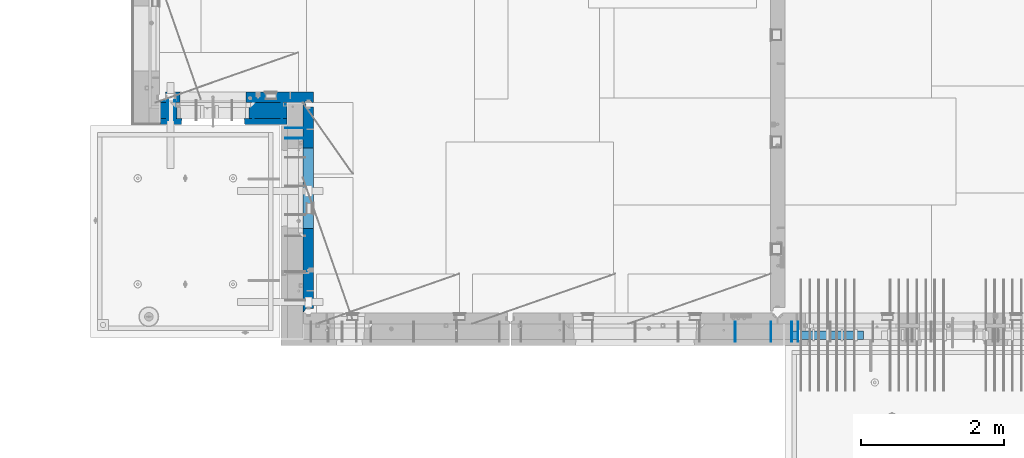
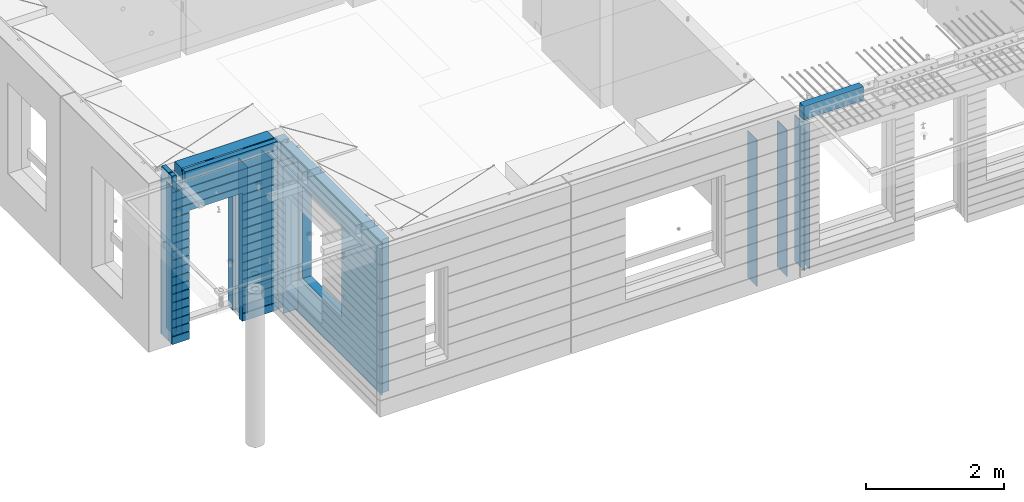
# One storey, part 229 of 352: 15 walls, 6 elements without a shape of their own.
"""IFC2X3 building model written with IfcOpenShell, lengths in millimetres."""

from ifc_helpers import new_model, si_unit, frame, origin_with_axes, place, context, subcontext, project, spatial, faceted_brep, material, type_object, element, aggregate, save


model = new_model("IFC2X3")

# Units and contexts
model_context = context("Model", 3, precision=1e-05, world=origin_with_axes())
body_context = subcontext(model_context, "Body", "Model", "MODEL_VIEW")
ifc_project = project(units=[si_unit("LENGTHUNIT", "METRE", prefix="MILLI"), si_unit("AREAUNIT", "SQUARE_METRE"), si_unit("VOLUMEUNIT", "CUBIC_METRE"), si_unit("MASSUNIT", "GRAM", prefix="KILO"), si_unit("TIMEUNIT", "SECOND"), si_unit("PLANEANGLEUNIT", "RADIAN"), si_unit("SOLIDANGLEUNIT", "STERADIAN"), si_unit("THERMODYNAMICTEMPERATUREUNIT", "DEGREE_CELSIUS"), si_unit("LUMINOUSINTENSITYUNIT", "LUMEN")], contexts=[model_context])

# Site, building, storey
site_placement = place(None, origin_with_axes())
site = spatial("IfcSite", under=ifc_project, at=site_placement, CompositionType="ELEMENT")
building_placement = place(site_placement, origin_with_axes())
building = spatial("IfcBuilding", under=site, at=building_placement, CompositionType="ELEMENT")
storey_placement = place(building_placement, origin_with_axes())
storey = spatial("IfcBuildingStorey", under=building, at=storey_placement, Name="6", CompositionType="ELEMENT", Elevation=0.0)

# Assembly, wall
assembly_1_placement = place(storey_placement, origin_with_axes())
assembly_1 = element("IfcElementAssembly", 1, at=assembly_1_placement, inside=storey, AssemblyPlace="NOTDEFINED", PredefinedType="REINFORCEMENT_UNIT")
ifc_material_1 = material(Name="Undefined")
wall_type_1 = type_object("IfcWallType", PredefinedType="NOTDEFINED")
wall_1_placement = place(assembly_1_placement, frame((16855.0, 7880.0, 98115.0), z_axis=(0.0, 0.0, 1.0), x_axis=(0.0, -1.0, 0.0)))
wall_1 = element("IfcWall", 2, at=wall_1_placement, type_object=wall_type_1, material=ifc_material_1, Name="(PD)", context=body_context, shape_type="Brep", body=[
    faceted_brep([(0.0, 5.0, -1300.0), (0.0, 5.0, 1300.0), (280.0, 5.0, 1300.0), (280.0, 5.0, -1300.0), (0.0, -5.0, 1300.0), (280.0, -5.0, 1300.0), (0.0, -5.0, -1300.0), (280.0, -5.0, -1300.0)], [[[0, 1, 2, 3]], [[1, 4, 5, 2]], [[4, 6, 7, 5]], [[6, 0, 3, 7]], [[5, 7, 3, 2]], [[6, 4, 1, 0]]]),
])

# Assembly, walls
assembly_2_placement = place(storey_placement, origin_with_axes())
assembly_2 = element("IfcElementAssembly", 3, at=assembly_2_placement, inside=storey, AssemblyPlace="NOTDEFINED", PredefinedType="REINFORCEMENT_UNIT")
wall_2_placement = place(assembly_2_placement, frame((16565.0, 7880.0, 98115.0), z_axis=(0.0, 0.0, 1.0), x_axis=(0.0, -1.0, 0.0)))
wall_2 = element("IfcWall", 4, at=wall_2_placement, type_object=wall_type_1, material=ifc_material_1, Name="(PD)", context=body_context, shape_type="Brep", body=[
    faceted_brep([(0.0, 5.0, -1300.0), (0.0, 5.0, 1300.0), (280.0, 5.0, 1300.0), (280.0, 5.0, -1300.0), (0.0, -5.0, 1300.0), (280.0, -5.0, 1300.0), (0.0, -5.0, -1300.0), (280.0, -5.0, -1300.0)], [[[0, 1, 2, 3]], [[1, 4, 5, 2]], [[4, 6, 7, 5]], [[6, 0, 3, 7]], [[5, 7, 3, 2]], [[6, 4, 1, 0]]]),
])
wall_3_placement = place(assembly_2_placement, frame((16065.0, 7880.0, 98115.0), z_axis=(0.0, 0.0, 1.0), x_axis=(0.0, -1.0, 0.0)))
wall_3 = element("IfcWall", 5, at=wall_3_placement, type_object=wall_type_1, material=ifc_material_1, Name="(PD)", context=body_context, shape_type="Brep", body=[
    faceted_brep([(0.0, 5.0, -1300.0), (0.0, 5.0, 1300.0), (280.0, 5.0, 1300.0), (280.0, 5.0, -1300.0), (0.0, -5.0, 1300.0), (280.0, -5.0, 1300.0), (0.0, -5.0, -1300.0), (280.0, -5.0, -1300.0)], [[[0, 1, 2, 3]], [[1, 4, 5, 2]], [[4, 6, 7, 5]], [[6, 0, 3, 7]], [[5, 7, 3, 2]], [[6, 4, 1, 0]]]),
])
aggregate(assembly_2, [wall_2, wall_3])

# Assembly, wall
assembly_3_placement = place(storey_placement, origin_with_axes())
assembly_3 = element("IfcElementAssembly", 6, at=assembly_3_placement, inside=storey, AssemblyPlace="NOTDEFINED", PredefinedType="REINFORCEMENT_UNIT")
wall_4_placement = place(assembly_3_placement, frame((8215.0, 10980.0, 98115.0), z_axis=(0.0, 0.0, 1.0), x_axis=(0.0, -1.0, 0.0)))
wall_4 = element("IfcWall", 7, at=wall_4_placement, type_object=wall_type_1, material=ifc_material_1, Name="(PD)", context=body_context, shape_type="Brep", body=[
    faceted_brep([(0.0, 5.0, -1300.0), (0.0, 5.0, 1300.0), (280.0, 5.0, 1300.0), (280.0, 5.0, -1300.0), (0.0, -5.0, 1300.0), (280.0, -5.0, 1300.0), (0.0, -5.0, -1300.0), (280.0, -5.0, -1300.0)], [[[0, 1, 2, 3]], [[1, 4, 5, 2]], [[4, 6, 7, 5]], [[6, 0, 3, 7]], [[5, 7, 3, 2]], [[6, 4, 1, 0]]]),
])

# Assembly, walls
assembly_4_placement = place(storey_placement, origin_with_axes())
assembly_4 = element("IfcElementAssembly", 8, at=assembly_4_placement, inside=storey, AssemblyPlace="NOTDEFINED", PredefinedType="REINFORCEMENT_UNIT")
wall_5_placement = place(assembly_4_placement, frame((10040.0, 10595.0, 98115.0), z_axis=(0.0, 0.0, 1.0), x_axis=(-1.0, 3.00000001838171e-08, 0.0)))
wall_5 = element("IfcWall", 9, at=wall_5_placement, type_object=wall_type_1, material=ifc_material_1, Name="(PD)", context=body_context, shape_type="Brep", body=[
    faceted_brep([(0.0, 5.0, -1300.0), (0.0, 5.0, 1300.0), (280.0, 5.0, 1300.0), (280.0, 5.0, -1300.0), (0.0, -5.0, 1300.0), (280.0, -5.0, 1300.0), (0.0, -5.0, -1300.0), (280.0, -5.0, -1300.0)], [[[0, 1, 2, 3]], [[1, 4, 5, 2]], [[4, 6, 7, 5]], [[6, 0, 3, 7]], [[5, 7, 3, 2]], [[6, 4, 1, 0]]]),
])
wall_6_placement = place(assembly_4_placement, frame((10040.0, 10450.0, 98115.0), z_axis=(0.0, 0.0, 1.0), x_axis=(-1.0, 3.00000001838171e-08, 0.0)))
wall_6 = element("IfcWall", 10, at=wall_6_placement, type_object=wall_type_1, material=ifc_material_1, Name="(PD)", context=body_context, shape_type="Brep", body=[
    faceted_brep([(0.0, 5.0, -1300.0), (0.0, 5.0, 1300.0), (280.0, 5.0, 1300.0), (280.0, 5.0, -1300.0), (0.0, -5.0, 1300.0), (280.0, -5.0, 1300.0), (0.0, -5.0, -1300.0), (280.0, -5.0, -1300.0)], [[[0, 1, 2, 3]], [[1, 4, 5, 2]], [[4, 6, 7, 5]], [[6, 0, 3, 7]], [[5, 7, 3, 2]], [[6, 4, 1, 0]]]),
])

# Wall
wall_7_placement = place(assembly_1_placement, frame((16945.0, 7880.0, 98115.0), z_axis=(0.0, 0.0, 1.0), x_axis=(0.0, -1.0, 0.0)))
wall_7 = element("IfcWall", 11, at=wall_7_placement, type_object=wall_type_1, material=ifc_material_1, Name="(PD)", context=body_context, shape_type="Brep", body=[
    faceted_brep([(0.0, 5.0, -1300.0), (0.0, 5.0, 1300.0), (280.0, 5.0, 1300.0), (280.0, 5.0, -1300.0), (0.0, -5.0, 1300.0), (280.0, -5.0, 1300.0), (0.0, -5.0, -1300.0), (280.0, -5.0, -1300.0)], [[[0, 1, 2, 3]], [[1, 4, 5, 2]], [[4, 6, 7, 5]], [[6, 0, 3, 7]], [[5, 7, 3, 2]], [[6, 4, 1, 0]]]),
])

aggregate(assembly_1, [wall_1, wall_7])

wall_8_placement = place(assembly_3_placement, frame((8115.0, 10980.0, 98115.0), z_axis=(0.0, 0.0, 1.0), x_axis=(0.0, -1.0, 0.0)))
wall_8 = element("IfcWall", 12, at=wall_8_placement, type_object=wall_type_1, material=ifc_material_1, Name="(PD)", context=body_context, shape_type="Brep", body=[
    faceted_brep([(0.0, 5.0, -1300.0), (0.0, 5.0, 1300.0), (280.0, 5.0, 1300.0), (280.0, 5.0, -1300.0), (0.0, -5.0, 1300.0), (280.0, -5.0, 1300.0), (0.0, -5.0, -1300.0), (280.0, -5.0, -1300.0)], [[[0, 1, 2, 3]], [[1, 4, 5, 2]], [[4, 6, 7, 5]], [[6, 0, 3, 7]], [[5, 7, 3, 2]], [[6, 4, 1, 0]]]),
])

wall_9_placement = place(assembly_3_placement, frame((9315.0, 10980.0, 98115.0), z_axis=(0.0, 0.0, 1.0), x_axis=(0.0, -1.0, 0.0)))
wall_9 = element("IfcWall", 13, at=wall_9_placement, type_object=wall_type_1, material=ifc_material_1, Name="(PD)", context=body_context, shape_type="Brep", body=[
    faceted_brep([(0.0, 5.0, -1300.0), (0.0, 5.0, 1300.0), (280.0, 5.0, 1300.0), (280.0, 5.0, -1300.0), (0.0, -5.0, 1300.0), (280.0, -5.0, 1300.0), (0.0, -5.0, -1300.0), (280.0, -5.0, -1300.0)], [[[0, 1, 2, 3]], [[1, 4, 5, 2]], [[4, 6, 7, 5]], [[6, 0, 3, 7]], [[5, 7, 3, 2]], [[6, 4, 1, 0]]]),
])

wall_10_placement = place(assembly_3_placement, frame((9715.0, 10980.0, 98115.0), z_axis=(0.0, 0.0, 1.0), x_axis=(0.0, -1.0, 0.0)))
wall_10 = element("IfcWall", 14, at=wall_10_placement, type_object=wall_type_1, material=ifc_material_1, Name="(PD)", context=body_context, shape_type="Brep", body=[
    faceted_brep([(0.0, 5.0, -1300.0), (0.0, 5.0, 1300.0), (280.0, 5.0, 1300.0), (280.0, 5.0, -1300.0), (0.0, -5.0, 1300.0), (280.0, -5.0, 1300.0), (0.0, -5.0, -1300.0), (280.0, -5.0, -1300.0)], [[[0, 1, 2, 3]], [[1, 4, 5, 2]], [[4, 6, 7, 5]], [[6, 0, 3, 7]], [[5, 7, 3, 2]], [[6, 4, 1, 0]]]),
])

# Assemblies, wall
assembly_5_placement = place(storey_placement, origin_with_axes())
assembly_5 = element("IfcElementAssembly", 15, at=assembly_5_placement, inside=storey, AssemblyPlace="NOTDEFINED", PredefinedType="REINFORCEMENT_UNIT")
assembly_6_placement = place(assembly_5_placement, origin_with_axes())
assembly_6 = element("IfcElementAssembly", 16, at=assembly_6_placement, Name="Steel Assembly", AssemblyPlace="NOTDEFINED", PredefinedType="NOTDEFINED")
aggregate(assembly_5, [assembly_6])
ifc_material_2 = material()
wall_type_2 = type_object("IfcWallType", PredefinedType="NOTDEFINED")
wall_11_placement = place(assembly_6_placement, frame((16859.9998568133, 7690.00021946163, 99590.0), z_axis=(0.0, 0.0, 1.0), x_axis=(1.0, 0.0, 0.0)))
wall_11 = element("IfcWall", 17, at=wall_11_placement, type_object=wall_type_2, material=ifc_material_2, context=body_context, shape_type="Brep", body=[
    faceted_brep([(0.0, 60.0, -120.0), (0.0, 60.0, 120.0), (1000.0, 60.0, 120.0), (1000.0, 60.0, -120.0), (0.0, -60.0, 120.0), (1000.0, -60.0, 120.0), (0.0, -60.0, -120.0), (1000.0, -60.0, -120.0)], [[[0, 1, 2, 3]], [[1, 4, 5, 2]], [[4, 6, 7, 5]], [[6, 0, 3, 7]], [[5, 7, 3, 2]], [[6, 4, 1, 0]]]),
])
aggregate(assembly_6, [wall_11])

# Wall
ifc_material_3 = material(Name="COS5gt")
wall_type_3 = type_object("IfcWallType", PredefinedType="NOTDEFINED")
wall_12_placement = place(assembly_3_placement, frame((9784.0, 10840.0, 98247.5), z_axis=(0.0, 0.0, 1.0), x_axis=(-1.0, 3.00000001838171e-08, 0.0)))
wall_12 = element("IfcWall", 18, at=wall_12_placement, type_object=wall_type_3, material=ifc_material_3, context=body_context, shape_type="Brep", body=[
    faceted_brep([(1699.0, -110.0, 1492.5), (1699.0, 90.0, 1492.5), (1699.0, 90.0, 1442.5), (1699.0, 110.0, 1442.5), (1699.0, 110.0, 1222.5), (1699.0, -110.0, 1222.5), (1549.0, 110.0, 1222.5), (1549.0, -110.0, 1222.5), (1549.0, -110.0, 1492.5), (1549.0, 110.0, 1442.5), (1549.0, 90.0, 1442.5), (1549.0, 90.0, 1492.5), (0.0, -110.0, -1492.5), (0.0, 90.0, -1492.5), (529.001442432404, 90.0, -1492.5), (529.001442432404, -110.0, -1492.5), (0.0, 90.0, -1442.5), (0.0, 110.0, -1442.5), (529.001442432404, 110.0, -1442.5), (529.001442432404, 90.0, -1442.5), (1769.0, 90.0, -1442.5), (1769.0, 90.0, -1492.5), (1539.0014424324, 90.0, -1492.5), (1539.0014424324, 90.0, -1442.5), (1769.0, 110.0, -1442.5), (1539.0014424324, 110.0, -1442.5), (1769.0, 110.0, 1442.5), (1769.0, 90.0, 1442.5), (1769.0, 90.0, 1492.5), (1769.0, -110.0, 1492.5), (1769.0, -110.0, -1492.5), (1539.0014424324, -110.0, -1492.5), (1539.0014424324, -110.0, 847.5), (1539.0014424324, 110.0, 847.5), (529.001442432404, -110.0, 847.5), (529.001442432404, 110.0, 847.5), (0.0, -110.0, 1492.5), (0.0, 90.0, 1492.5), (0.0, 90.0, 1442.5), (0.0, 110.0, 1442.5)], [[[0, 1, 2, 3, 4, 5]], [[5, 4, 6, 7]], [[8, 7, 6, 9, 10, 11]], [[12, 13, 14, 15]], [[16, 17, 18, 19]], [[20, 21, 22, 23]], [[24, 20, 23, 25]], [[26, 27, 28, 29, 30, 21, 20, 24]], [[21, 30, 31, 22]], [[32, 33, 25, 23, 22, 31]], [[34, 35, 33, 32]], [[15, 14, 19, 18, 35, 34]], [[13, 16, 19, 14]], [[13, 12, 36, 37, 38, 39, 17, 16]], [[37, 36, 8, 11]], [[38, 37, 11, 10]], [[39, 38, 10, 9]], [[4, 3, 26, 24, 25, 33, 35, 18, 17, 39, 9, 6]], [[27, 26, 3, 2]], [[28, 27, 2, 1]], [[29, 28, 1, 0]], [[36, 12, 15, 34, 32, 31, 30, 29, 0, 5, 7, 8]]]),
])

ifc_material_4 = material(Name="CONCRETE/C30/37")
wall_type_4 = type_object("IfcWallType", PredefinedType="NOTDEFINED")
wall_13_placement = place(assembly_3_placement, frame((9784.0, 10687.5, 98247.5), z_axis=(0.0, 0.0, 1.0), x_axis=(-1.0, 3.00000001838171e-08, 0.0)))
wall_13 = element("IfcWall", 19, at=wall_13_placement, type_object=wall_type_4, material=ifc_material_4, context=body_context, shape_type="Brep", body=[
    faceted_brep([(1699.0, -42.5, 1492.5), (1699.0, 42.5, 1492.5), (1699.0, 42.5, 1356.99999988925), (1699.0, 32.4999991126988, 1355.00000040044), (1699.0, 32.4999992506928, 1344.99999999921), (1699.0, 42.5, 1342.99999994476), (1699.0, 42.5, 1222.5), (1699.0, -42.5, 1222.5), (1549.0, 42.5, 1222.5), (1549.0, -42.5, 1222.5), (1549.0, -42.5, 1492.5), (1549.0, 42.5, 1342.99999994476), (1549.0, 32.4999992506928, 1344.99999999921), (1549.0, 32.4999991126988, 1355.00000040044), (1549.0, 42.5, 1356.99999988925), (1549.0, 42.5, 1492.5), (1478.99938360887, 42.5, 606.999999889245), (1769.0, 42.5, 606.999999889245), (1769.0, 32.4999991126988, 605.00000040044), (1477.8227168378, 32.4999991126988, 605.00000040044), (1769.0, 32.4999992506928, 594.999999999214), (1477.82271685404, 32.4999992506928, 594.999999999214), (1769.0, 42.5, 592.999999944761), (1478.99938360887, 42.5, 592.999999944761), (1769.0, 42.5, 456.999999889245), (1478.99938360887, 42.5, 456.999999889245), (1769.0, 32.4999991126988, 455.00000040044), (1477.8227168378, 32.4999991126988, 455.00000040044), (1769.0, 32.4999992506928, 444.999999999214), (1477.82271685404, 32.4999992506928, 444.999999999214), (1769.0, 42.5, 442.999999944761), (1478.99938360887, 42.5, 442.999999944761), (1769.0, 42.5, 306.999999889245), (1478.99938360887, 42.5, 306.999999889245), (1769.0, 32.4999991126988, 305.00000040044), (1477.8227168378, 32.4999991126988, 305.00000040044), (1769.0, 32.4999992506928, 294.999999999214), (1477.82271685404, 32.4999992506928, 294.999999999214), (1769.0, 42.5, 292.999999944761), (1478.99938360887, 42.5, 292.999999944761), (1769.0, 42.5, 156.999999889245), (1478.99938360887, 42.5, 156.999999889245), (1769.0, 32.4999991126988, 155.00000040044), (1477.8227168378, 32.4999991126988, 155.00000040044), (1769.0, 32.4999992506928, 144.999999999214), (1477.82271685404, 32.4999992506928, 144.999999999214), (1769.0, 42.5, 142.999999944761), (1478.99938360887, 42.5, 142.999999944761), (1769.0, 42.5, 6.99999988924537), (1478.99938360887, 42.5, 6.99999988924537), (1769.0, 32.4999991126988, 5.0000004004396), (1477.8227168378, 32.4999991126988, 5.0000004004396), (1769.0, 32.4999992506928, -5.0000000007858), (1477.82271685404, 32.4999992506928, -5.0000000007858), (1769.0, 42.5, -7.00000005523907), (1478.99938360887, 42.5, -7.00000005523907), (1769.0, 42.5, -143.000000110755), (1478.99938360887, 42.5, -143.000000110755), (1769.0, 32.4999991126988, -144.99999959956), (1477.8227168378, 32.4999991126988, -144.99999959956), (1769.0, 32.4999992506928, -155.000000000786), (1477.82271685404, 32.4999992506928, -155.000000000786), (1769.0, 42.5, -157.000000055239), (1478.99938360887, 42.5, -157.000000055239), (1769.0, 42.5, -293.000000110755), (1478.99938360887, 42.5, -293.000000110755), (1769.0, 32.4999991126988, -294.99999959956), (1477.8227168378, 32.4999991126988, -294.99999959956), (1769.0, 32.4999992506928, -305.000000000786), (1477.82271685404, 32.4999992506928, -305.000000000786), (1769.0, 42.5, -307.000000055239), (1478.99938360887, 42.5, -307.000000055239), (1769.0, 42.5, -443.000000110755), (1478.99938360887, 42.5, -443.000000110755), (1769.0, 32.4999991126988, -444.99999959956), (1477.8227168378, 32.4999991126988, -444.99999959956), (1769.0, 32.4999992506928, -455.000000000786), (1477.82271685404, 32.4999992506928, -455.000000000786), (1769.0, 42.5, -457.000000055239), (1478.99938360887, 42.5, -457.000000055239), (1769.0, 42.5, -593.000000110755), (1478.99938360887, 42.5, -593.000000110755), (1769.0, 32.4999991126988, -594.99999959956), (1477.8227168378, 32.4999991126988, -594.99999959956), (1769.0, 32.4999992506928, -605.000000000786), (1477.82271685404, 32.4999992506928, -605.000000000786), (1769.0, 42.5, -607.000000055239), (1478.99938360887, 42.5, -607.000000055239), (1769.0, 42.5, -743.000000110755), (1478.99938360887, 42.5, -743.000000110755), (1769.0, 32.4999991126988, -744.99999959956), (1477.8227168378, 32.4999991126988, -744.99999959956), (1769.0, 32.4999992506928, -755.000000000786), (1477.82271685404, 32.4999992506928, -755.000000000786), (1769.0, 42.5, -757.000000055239), (1478.99938360887, 42.5, -757.000000055239), (1769.0, 42.5, -893.000000110755), (1478.99938360887, 42.5, -893.000000110755), (1769.0, 32.4999991126988, -894.99999959956), (1477.8227168378, 32.4999991126988, -894.99999959956), (1769.0, 32.4999992506928, -905.000000000786), (1477.82271685404, 32.4999992506928, -905.000000000786), (1769.0, 42.5, -907.000000055239), (1478.99938360887, 42.5, -907.000000055239), (1769.0, 42.5, -1043.00000011075), (1478.99938360887, 42.5, -1043.00000011075), (1769.0, 32.4999991126988, -1044.99999959956), (1477.8227168378, 32.4999991126988, -1044.99999959956), (1769.0, 32.4999992506928, -1055.00000000079), (1477.82271685404, 32.4999992506928, -1055.00000000079), (1769.0, 42.5, -1057.00000005524), (1478.99938360887, 42.5, -1057.00000005524), (1769.0, 42.5, -1193.00000011075), (1478.99938360887, 42.5, -1193.00000011075), (1769.0, 32.4999991126988, -1194.99999959956), (1477.8227168378, 32.4999991126988, -1194.99999959956), (1769.0, 32.4999992506928, -1205.00000000079), (1477.82271685404, 32.4999992506928, -1205.00000000079), (1769.0, 42.5, -1207.00000005524), (1478.99938360887, 42.5, -1207.00000005524), (1769.0, 42.5, -1343.00000011075), (1478.99938360887, 42.5, -1343.00000011075), (1769.0, 32.4999991126988, -1344.99999959956), (1477.8227168378, 32.4999991126988, -1344.99999959956), (1769.0, 32.4999992506928, -1355.00000000079), (1477.82271685404, 32.4999992506928, -1355.00000000079), (1769.0, 42.5, -1357.00000005524), (1478.99938360887, 42.5, -1357.00000005524), (1769.0, 42.5, -1492.5), (1478.99938360887, 42.5, -1492.5), (1769.0, -42.5, -1492.5), (1468.99771694221, -42.5, -1492.5), (599.001442432404, 42.5, 782.5), (1469.0014424324, 42.5, 782.5), (1478.99938360887, 42.5, 782.5), (1468.99771694221, -42.5, 787.502857142856), (599.001050275541, -42.5, 787.502857142856), (588.999383608874, 42.5, 782.5), (1478.99938360887, 42.5, 742.999999944761), (1468.99771694221, -42.5, 782.5), (1478.99938360887, 42.5, 756.999999889245), (1477.82271683781, 32.4999991126988, 755.00000040044), (1477.82271685404, 32.4999992506928, 744.999999999214), (1769.0, 42.5, 742.999999944761), (1769.0, 32.4999992506928, 744.999999999214), (1769.0, 32.4999991126988, 755.00000040044), (1769.0, 42.5, 756.999999889245), (0.0, 32.4999991127006, 905.00000040044), (1769.0, 32.4999991126988, 905.00000040044), (1769.0, 32.4999992506928, 894.999999999214), (0.0, 32.4999992507037, 894.999999999258), (0.0, 42.5, 906.999999889245), (1769.0, 42.5, 906.999999889245), (0.0, 42.5, 1042.99999994476), (1769.0, 42.5, 1042.99999994476), (0.0, 32.4999992507037, 1044.99999999926), (1769.0, 32.4999992506928, 1044.99999999921), (0.0, 32.4999991127006, 1055.00000040044), (1769.0, 32.4999991126988, 1055.00000040044), (0.0, 42.5, 1056.99999988925), (1769.0, 42.5, 1056.99999988925), (0.0, 42.5, 1192.99999994476), (1769.0, 42.5, 1192.99999994476), (0.0, 32.4999992507037, 1194.99999999926), (1769.0, 32.4999992506928, 1194.99999999921), (0.0, 32.4999991127006, 1205.00000040044), (1769.0, 32.4999991126988, 1205.00000040044), (0.0, 42.5, 1206.99999988925), (1769.0, 42.5, 1206.99999988925), (1769.0, 42.5, 1492.5), (1769.0, -42.5, 1492.5), (1769.0, 42.5, 892.999999944761), (1769.0, 42.5, 1342.99999994476), (1769.0, 32.4999992506928, 1344.99999999921), (1769.0, 32.4999991126988, 1355.00000040044), (1769.0, 42.5, 1356.99999988925), (0.0, 42.5, 892.999999944761), (588.999383608874, 42.5, 756.999999889245), (0.0, 42.5, 756.999999889245), (588.999383608874, 42.5, -1492.5), (0.0, 42.5, -1492.5), (0.0, 42.5, -1357.00000005524), (588.999383608874, 42.5, -1357.00000005524), (0.0, 32.4999992507037, -1355.00000000074), (590.176050363707, 32.4999992506928, -1355.00000000079), (0.0, 32.4999991127006, -1344.99999959956), (590.176050379945, 32.4999991126988, -1344.99999959956), (0.0, 42.5, -1343.00000011075), (588.999383608874, 42.5, -1343.00000011075), (0.0, 42.5, -1207.00000005524), (588.999383608874, 42.5, -1207.00000005524), (0.0, 32.4999992507037, -1205.00000000074), (590.176050363709, 32.4999992506928, -1205.00000000079), (0.0, 32.4999991127006, -1194.99999959956), (590.176050379947, 32.4999991126988, -1194.99999959956), (0.0, 42.5, -1193.00000011075), (588.999383608874, 42.5, -1193.00000011075), (0.0, 42.5, -1057.00000005524), (588.999383608874, 42.5, -1057.00000005524), (0.0, 32.4999992507037, -1055.00000000074), (590.176050363711, 32.4999992506928, -1055.00000000079), (0.0, 32.4999991127006, -1044.99999959956), (590.176050379947, 32.4999991126988, -1044.99999959956), (0.0, 42.5, -1043.00000011075), (588.999383608874, 42.5, -1043.00000011075), (0.0, 42.5, -907.000000055239), (588.999383608874, 42.5, -907.000000055239), (0.0, 32.4999992507037, -905.000000000742), (590.176050363711, 32.4999992506928, -905.000000000786), (0.0, 32.4999991127006, -894.99999959956), (590.176050379947, 32.4999991126988, -894.99999959956), (0.0, 42.5, -893.000000110755), (588.999383608874, 42.5, -893.000000110755), (0.0, 42.5, -757.000000055239), (588.999383608874, 42.5, -757.000000055239), (0.0, 32.4999992507037, -755.000000000742), (590.176050363711, 32.4999992506928, -755.000000000786), (0.0, 32.4999991127006, -744.99999959956), (590.176050379947, 32.4999991126988, -744.99999959956), (0.0, 42.5, -743.000000110755), (588.999383608874, 42.5, -743.000000110755), (0.0, 42.5, -607.000000055239), (588.999383608874, 42.5, -607.000000055239), (3.63797880709171e-12, 32.4999992507037, -605.000000000742), (590.176050363709, 32.4999992506928, -605.000000000786), (3.63797880709171e-12, 32.4999991127006, -594.99999959956), (590.176050379947, 32.4999991126988, -594.99999959956), (0.0, 42.5, -593.000000110755), (588.999383608874, 42.5, -593.000000110755), (0.0, 42.5, -457.000000055239), (588.999383608874, 42.5, -457.000000055239), (0.0, 32.4999992507037, -455.000000000742), (590.176050363711, 32.4999992506928, -455.000000000786), (0.0, 32.4999991127006, -444.99999959956), (590.176050379947, 32.4999991126988, -444.99999959956), (0.0, 42.5, -443.000000110755), (588.999383608874, 42.5, -443.000000110755), (0.0, 42.5, -307.000000055239), (588.999383608874, 42.5, -307.000000055239), (0.0, 32.4999992507037, -305.000000000742), (590.176050363711, 32.4999992506928, -305.000000000786), (0.0, 32.4999991127006, -294.99999959956), (590.176050379947, 32.4999991126988, -294.99999959956), (0.0, 42.5, -293.000000110755), (588.999383608874, 42.5, -293.000000110755), (0.0, 42.5, -157.000000055239), (588.999383608874, 42.5, -157.000000055239), (3.63797880709171e-12, 32.4999992507037, -155.000000000742), (590.176050363707, 32.4999992506928, -155.000000000786), (3.63797880709171e-12, 32.4999991127006, -144.99999959956), (590.176050379945, 32.4999991126988, -144.99999959956), (0.0, 42.5, -143.000000110755), (588.999383608874, 42.5, -143.000000110755), (0.0, 42.5, -7.00000005523907), (588.999383608874, 42.5, -7.00000005523907), (0.0, 32.4999992507037, -5.00000000074215), (590.176050363705, 32.4999992506928, -5.0000000007858), (0.0, 32.4999991127006, 5.0000004004396), (590.176050379941, 32.4999991126988, 5.0000004004396), (0.0, 42.5, 6.99999988924537), (588.999383608874, 42.5, 6.99999988924537), (0.0, 42.5, 142.999999944761), (588.999383608874, 42.5, 142.999999944761), (-3.63797880709171e-12, 32.4999992507037, 144.999999999258), (590.176050363705, 32.4999992506928, 144.999999999214), (-3.63797880709171e-12, 32.4999991127006, 155.00000040044), (590.176050379943, 32.4999991126988, 155.00000040044), (0.0, 42.5, 156.999999889245), (588.999383608874, 42.5, 156.999999889245), (0.0, 42.5, 292.999999944761), (588.999383608874, 42.5, 292.999999944761), (-3.63797880709171e-12, 32.4999992507037, 294.999999999258), (590.176050363703, 32.4999992506928, 294.999999999214), (-3.63797880709171e-12, 32.4999991127006, 305.00000040044), (590.17605037994, 32.4999991126988, 305.00000040044), (0.0, 42.5, 306.999999889245), (588.999383608874, 42.5, 306.999999889245), (0.0, 42.5, 442.999999944761), (588.999383608874, 42.5, 442.999999944761), (0.0, 32.4999992507037, 444.999999999258), (590.176050363702, 32.4999992506928, 444.999999999214), (0.0, 32.4999991127006, 455.00000040044), (590.176050379938, 32.4999991126988, 455.00000040044), (0.0, 42.5, 456.999999889245), (588.999383608874, 42.5, 456.999999889245), (0.0, 42.5, 592.999999944761), (588.999383608874, 42.5, 592.999999944761), (3.63797880709171e-12, 32.4999992507037, 594.999999999258), (590.176050363702, 32.4999992506928, 594.999999999214), (3.63797880709171e-12, 32.4999991127006, 605.00000040044), (590.17605037994, 32.4999991126988, 605.00000040044), (0.0, 42.5, 606.999999889245), (588.999383608874, 42.5, 606.999999889245), (0.0, 42.5, 742.999999944761), (588.999383608874, 42.5, 742.999999944761), (0.0, 32.4999992507037, 744.999999999258), (590.176050363705, 32.4999992506928, 744.999999999214), (0.0, 32.4999991127006, 755.00000040044), (590.176050379943, 32.4999991126988, 755.00000040044), (599.001050275541, -42.5, 782.5), (599.001050275539, -42.5, -1492.5), (0.0, -42.5, -1492.5), (-3.63797880709171e-12, 32.4999992507037, 1344.99999999926), (0.0, 42.5, 1342.99999994476), (0.0, -42.5, 1492.5), (0.0, 42.5, 1492.5), (0.0, 42.5, 1356.99999988925), (-3.63797880709171e-12, 32.4999991127006, 1355.00000040044)], [[[0, 1, 2, 3, 4, 5, 6, 7]], [[7, 6, 8, 9]], [[10, 9, 8, 11, 12, 13, 14, 15]], [[16, 17, 18, 19]], [[19, 18, 20, 21]], [[21, 20, 22, 23]], [[24, 25, 23, 22]], [[25, 24, 26, 27]], [[27, 26, 28, 29]], [[29, 28, 30, 31]], [[32, 33, 31, 30]], [[33, 32, 34, 35]], [[35, 34, 36, 37]], [[37, 36, 38, 39]], [[40, 41, 39, 38]], [[41, 40, 42, 43]], [[43, 42, 44, 45]], [[45, 44, 46, 47]], [[48, 49, 47, 46]], [[49, 48, 50, 51]], [[51, 50, 52, 53]], [[53, 52, 54, 55]], [[56, 57, 55, 54]], [[57, 56, 58, 59]], [[59, 58, 60, 61]], [[61, 60, 62, 63]], [[64, 65, 63, 62]], [[65, 64, 66, 67]], [[67, 66, 68, 69]], [[69, 68, 70, 71]], [[72, 73, 71, 70]], [[73, 72, 74, 75]], [[75, 74, 76, 77]], [[77, 76, 78, 79]], [[80, 81, 79, 78]], [[81, 80, 82, 83]], [[83, 82, 84, 85]], [[85, 84, 86, 87]], [[88, 89, 87, 86]], [[89, 88, 90, 91]], [[91, 90, 92, 93]], [[93, 92, 94, 95]], [[96, 97, 95, 94]], [[97, 96, 98, 99]], [[99, 98, 100, 101]], [[101, 100, 102, 103]], [[104, 105, 103, 102]], [[105, 104, 106, 107]], [[107, 106, 108, 109]], [[109, 108, 110, 111]], [[112, 113, 111, 110]], [[113, 112, 114, 115]], [[115, 114, 116, 117]], [[117, 116, 118, 119]], [[120, 121, 119, 118]], [[121, 120, 122, 123]], [[123, 122, 124, 125]], [[125, 124, 126, 127]], [[128, 129, 127, 126]], [[128, 130, 131, 129]], [[132, 133, 134, 135, 136, 137]], [[138, 16, 19, 21, 23, 25, 27, 29, 31, 33, 35, 37, 39, 41, 43, 45, 47, 49, 51, 53, 55, 57, 59, 61, 63, 65, 67, 69, 71, 73, 75, 77, 79, 81, 83, 85, 87, 89, 91, 93, 95, 97, 99, 101, 103, 105, 107, 109, 111, 113, 115, 117, 119, 121, 123, 125, 127, 129, 131, 139, 135, 134, 140, 141, 142]], [[17, 16, 138, 143]], [[142, 144, 143, 138]], [[141, 145, 144, 142]], [[140, 146, 145, 141]], [[147, 148, 149, 150]], [[151, 152, 148, 147]], [[152, 151, 153, 154]], [[155, 156, 154, 153]], [[157, 158, 156, 155]], [[159, 160, 158, 157]], [[160, 159, 161, 162]], [[163, 164, 162, 161]], [[165, 166, 164, 163]], [[167, 168, 166, 165]], [[169, 170, 130, 128, 126, 124, 122, 120, 118, 116, 114, 112, 110, 108, 106, 104, 102, 100, 98, 96, 94, 92, 90, 88, 86, 84, 82, 80, 78, 76, 74, 72, 70, 68, 66, 64, 62, 60, 58, 56, 54, 52, 50, 48, 46, 44, 42, 40, 38, 36, 34, 32, 30, 28, 26, 24, 22, 20, 18, 17, 143, 144, 145, 146, 171, 149, 148, 152, 154, 156, 158, 160, 162, 164, 166, 168, 172, 173, 174, 175]], [[150, 149, 171, 176]], [[146, 140, 134, 133, 132, 137, 177, 178, 176, 171]], [[179, 180, 181, 182]], [[183, 184, 182, 181]], [[185, 186, 184, 183]], [[187, 188, 186, 185]], [[188, 187, 189, 190]], [[191, 192, 190, 189]], [[193, 194, 192, 191]], [[195, 196, 194, 193]], [[196, 195, 197, 198]], [[199, 200, 198, 197]], [[201, 202, 200, 199]], [[203, 204, 202, 201]], [[204, 203, 205, 206]], [[207, 208, 206, 205]], [[209, 210, 208, 207]], [[211, 212, 210, 209]], [[212, 211, 213, 214]], [[215, 216, 214, 213]], [[217, 218, 216, 215]], [[219, 220, 218, 217]], [[220, 219, 221, 222]], [[223, 224, 222, 221]], [[225, 226, 224, 223]], [[227, 228, 226, 225]], [[228, 227, 229, 230]], [[231, 232, 230, 229]], [[233, 234, 232, 231]], [[235, 236, 234, 233]], [[236, 235, 237, 238]], [[239, 240, 238, 237]], [[241, 242, 240, 239]], [[243, 244, 242, 241]], [[244, 243, 245, 246]], [[247, 248, 246, 245]], [[249, 250, 248, 247]], [[251, 252, 250, 249]], [[252, 251, 253, 254]], [[255, 256, 254, 253]], [[257, 258, 256, 255]], [[259, 260, 258, 257]], [[260, 259, 261, 262]], [[263, 264, 262, 261]], [[265, 266, 264, 263]], [[267, 268, 266, 265]], [[268, 267, 269, 270]], [[271, 272, 270, 269]], [[273, 274, 272, 271]], [[275, 276, 274, 273]], [[276, 275, 277, 278]], [[279, 280, 278, 277]], [[281, 282, 280, 279]], [[283, 284, 282, 281]], [[284, 283, 285, 286]], [[287, 288, 286, 285]], [[289, 290, 288, 287]], [[291, 292, 290, 289]], [[292, 291, 293, 294]], [[295, 296, 294, 293]], [[297, 298, 296, 295]], [[178, 177, 298, 297]], [[137, 136, 299, 300, 179, 182, 184, 186, 188, 190, 192, 194, 196, 198, 200, 202, 204, 206, 208, 210, 212, 214, 216, 218, 220, 222, 224, 226, 228, 230, 232, 234, 236, 238, 240, 242, 244, 246, 248, 250, 252, 254, 256, 258, 260, 262, 264, 266, 268, 270, 272, 274, 276, 278, 280, 282, 284, 286, 288, 290, 292, 294, 296, 298, 177]], [[301, 180, 179, 300]], [[302, 303, 167, 165, 163, 161, 159, 157, 155, 153, 151, 147, 150, 176, 178, 297, 295, 293, 291, 289, 287, 285, 283, 281, 279, 277, 275, 273, 271, 269, 267, 265, 263, 261, 259, 257, 255, 253, 251, 249, 247, 245, 243, 241, 239, 237, 235, 233, 231, 229, 227, 225, 223, 221, 219, 217, 215, 213, 211, 209, 207, 205, 203, 201, 199, 197, 195, 193, 191, 189, 187, 185, 183, 181, 180, 301, 304, 305, 306, 307]], [[305, 304, 10, 15]], [[306, 305, 15, 14]], [[307, 306, 14, 13]], [[302, 307, 13, 12]], [[303, 302, 12, 11]], [[6, 5, 172, 168, 167, 303, 11, 8]], [[173, 172, 5, 4]], [[174, 173, 4, 3]], [[175, 174, 3, 2]], [[169, 175, 2, 1]], [[170, 169, 1, 0]], [[304, 301, 300, 299, 136, 135, 139, 131, 130, 170, 0, 7, 9, 10]]]),
])

ifc_material_5 = material(Name="CONCRETE/C25/30")
wall_type_5 = type_object("IfcWallType", PredefinedType="NOTDEFINED")
wall_14_placement = place(assembly_4_placement, frame((10085.0, 8000.0, 98112.5), z_axis=(0.0, 0.0, 1.0), x_axis=(0.0, 1.0, 0.0)))
wall_14 = element("IfcWall", 20, at=wall_14_placement, type_object=wall_type_5, material=ifc_material_5, context=body_context, shape_type="Brep", body=[
    faceted_brep([(2885.0, -75.0, 1357.5), (2885.0, -75.0, -1357.5), (2885.0, 27.0, -1357.5), (2885.0, 27.0, 1357.5), (2934.99999772087, 40.0, 1357.5), (2934.99999772087, 75.0, 1357.5), (15.0, 75.0, 1357.5), (15.0, 65.0, 1357.5), (65.0, 35.0, 1357.5), (65.0, -75.0, 1357.5), (15.0, 75.0, -1357.5), (15.0, 65.0, -1357.5), (65.0, 35.0, -1357.5), (65.0, -75.0, -1357.5), (1380.0, -75.0, -1357.5), (1380.0, -74.9999999938009, -1207.49999999684), (1550.0, -74.9999999938009, -1207.49999999684), (1550.0, -75.0, -1357.5), (1185.00311728789, -75.0000000030959, -682.5), (1185.00311728789, -75.0000000030959, 952.5), (2315.00311728789, -75.0000000030959, 952.5), (2315.00311728789, -75.0000000030959, -682.5), (1380.0, -72.9999999938009, -1207.49999999684), (1550.0, -72.9999999938009, -1207.49999999684), (1380.0, -72.9999999938009, -1357.4999999999), (1550.0, -72.9999999938009, -1357.4999999999), (2934.99999772087, 75.0, -1357.5), (2934.99999772087, 40.0, -1357.5), (1189.05717134203, 75.0, -678.445945945859), (2310.94906323375, 75.0, -678.445945945859), (2310.94906323375, 75.0, 948.445945945859), (1189.05717134203, 75.0, 948.445945945859)], [[[0, 1, 2, 3]], [[4, 5, 6, 7, 8, 9, 0, 3]], [[6, 10, 11, 7]], [[7, 11, 12, 8]], [[9, 8, 12, 13]], [[1, 0, 9, 13, 14, 15, 16, 17], [18, 19, 20, 21]], [[15, 22, 23, 16]], [[14, 24, 22, 15]], [[25, 23, 22, 24]], [[16, 23, 25, 17]], [[24, 14, 13, 12, 11, 10, 26, 27, 2, 1, 17, 25]], [[3, 2, 27, 4]], [[26, 5, 4, 27]], [[10, 6, 5, 26], [28, 29, 30, 31]], [[20, 30, 29, 21]], [[19, 31, 30, 20]], [[18, 28, 31, 19]], [[21, 29, 28, 18]]]),
])

aggregate(assembly_4, [wall_5, wall_6, wall_14])

wall_15_placement = place(assembly_3_placement, frame((10160.0, 11025.0, 98112.5), z_axis=(0.0, 0.0, 1.0), x_axis=(-1.0, 3.00000001838171e-08, 0.0)))
wall_15 = element("IfcWall", 21, at=wall_15_placement, type_object=wall_type_5, material=ifc_material_5, context=body_context, shape_type="Brep", body=[
    faceted_brep([(47.9999996848892, 54.9999994175323, 1357.5), (47.9999996848892, 54.9999994175323, -1357.5), (34.999999998452, 55.0000022791301, -1357.5), (34.999999998452, 55.0000022791301, 1357.5), (24.999999998452, 75.0000022791301, 1357.5), (24.999999998452, 75.0, -1357.5), (124.999999998452, 75.0, 1357.5), (124.999999998452, 75.0, -1357.5), (114.999999998452, 55.0000022791301, -1357.5), (114.999999998452, 55.0000022791301, 1357.5), (101.99999958942, 54.999999390373, 1357.5), (101.99999958942, 54.999999390373, -1357.5), (945.001442432404, -75.0, -1357.5), (949.055496486459, 75.0, -1357.5), (949.055496486457, 75.0, 948.445945945947), (945.001442432404, -75.0, 952.5), (0.0, -75.0, -1357.5), (0.0, 75.0, -1357.5), (2145.0, 75.0, 1357.5), (2145.0, 75.0, -1357.5), (1870.94738837835, 75.0, -1357.5), (1870.94738837835, 75.0, 948.445945945947), (2145.0, 45.0, 1357.5), (2145.0, 45.0, -1357.5), (2074.9999995581, 32.0, 1357.5), (2074.9999995581, 32.0, -1357.5), (2074.9999995581, -75.0, 1357.5), (2074.9999995581, -75.0, -1357.5), (1875.0014424324, -75.0, -1357.5), (1875.0014424324, -75.0, 952.5), (0.0, -75.0, 1357.5), (0.0, 75.0, 1357.5)], [[[0, 1, 2, 3]], [[4, 3, 2, 5]], [[6, 7, 8, 9]], [[10, 9, 8, 11]], [[10, 11, 1, 0]], [[12, 13, 14, 15]], [[1, 11, 8, 7, 13, 12, 16, 17, 5, 2]], [[18, 19, 20, 21, 14, 13, 7, 6]], [[19, 18, 22, 23]], [[24, 25, 23, 22]], [[26, 27, 25, 24]], [[19, 23, 25, 27, 28, 20]], [[20, 28, 29, 21]], [[15, 14, 21, 29]], [[28, 27, 26, 30, 16, 12, 15, 29]], [[16, 30, 31, 17]], [[17, 31, 4, 5]], [[31, 30, 26, 24, 22, 18, 6, 9, 10, 0, 3, 4]]]),
])

aggregate(assembly_3, [wall_4, wall_8, wall_9, wall_10, wall_13, wall_12, wall_15])

save(model, "model.ifc")
